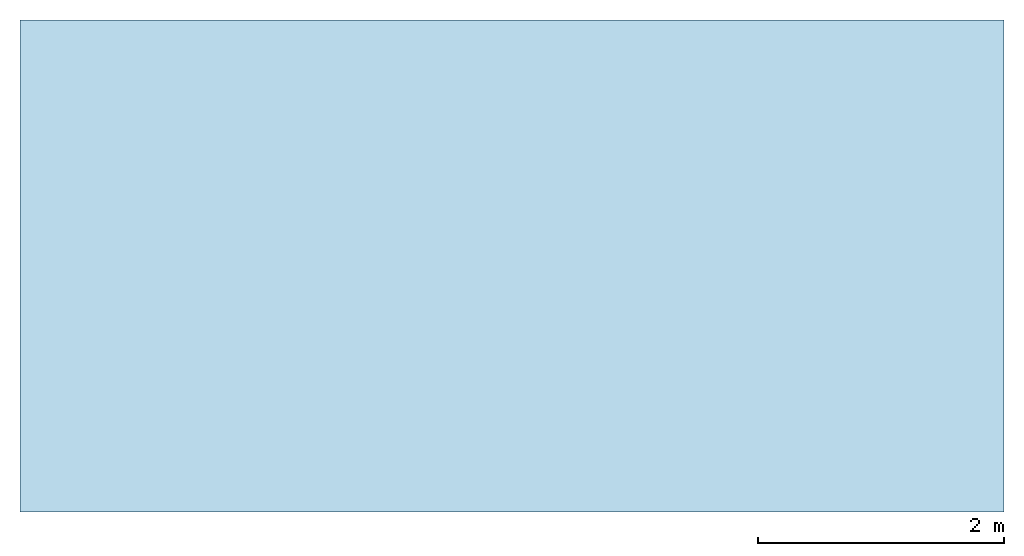
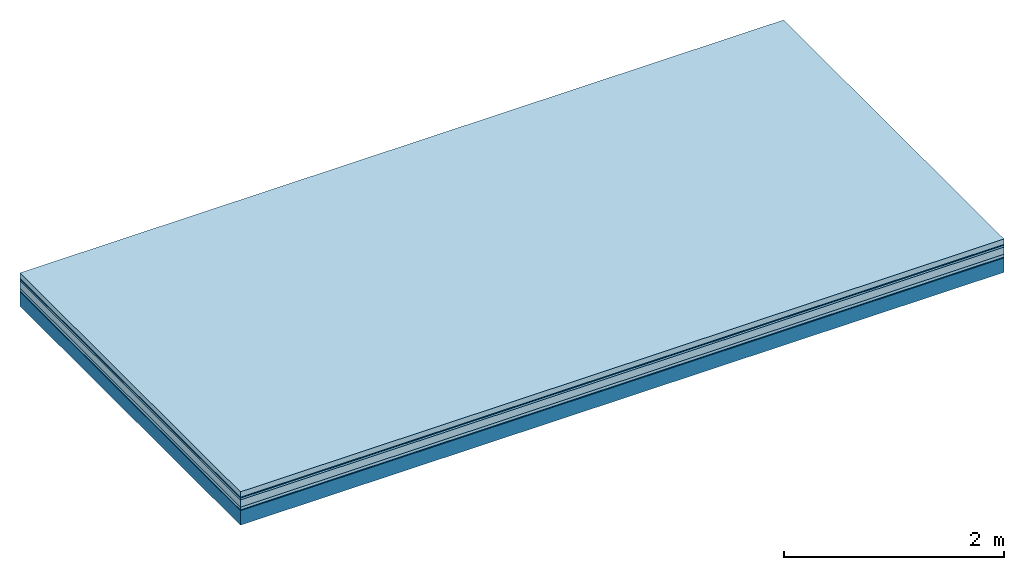
# One storey: 6 plates, 1 member, 1 element without a shape of its own.
"""IFC4 building model written with IfcOpenShell, lengths in metres."""

import ifcopenshell
import ifcopenshell.guid

model = None  # the IFC model being written
_history = None  # IfcOwnerHistory: only IFC2X3 demands one
_inside = {}  # id of a spatial element -> (the spatial element, [elements in it])
_under = {}  # id of a project, library or spatial element -> (it, [spatial elements below it])
_declared = {}  # id of a project -> (the project, [libraries it declares])
_typed = {}  # id of a type object -> (the type object, [elements of that type])
_made_of = {}  # id of a material, layer set ... -> (it, [elements and type objects made of it])


def new_model(schema):
    """Start an empty IFC model of exactly this schema.

    Asked for "IFC4X3", IfcOpenShell would pick the latest addendum, in which some entities
    have other attributes; the version numbers below select the first issue.
    IFC2X3 requires an IfcOwnerHistory on every rooted entity: one is made here for all.
    """
    global model, _history
    if schema == "IFC4X3":
        model = ifcopenshell.file(schema_version=(4, 3, 0, 0))
    else:
        model = ifcopenshell.file(schema=schema)
    _inside.clear()
    _under.clear()
    _declared.clear()
    _typed.clear()
    _made_of.clear()
    _history = None
    if model.schema == "IFC2X3":
        org = make("IfcOrganization", Name="unknown")
        user = make(
            "IfcPersonAndOrganization",
            ThePerson=make("IfcPerson", FamilyName="unknown"),
            TheOrganization=org,
        )
        app = make(
            "IfcApplication",
            ApplicationDeveloper=org,
            Version="unknown",
            ApplicationFullName="unknown",
            ApplicationIdentifier="unknown",
        )
        _history = make(
            "IfcOwnerHistory",
            OwningUser=user,
            OwningApplication=app,
            ChangeAction="ADDED",
            CreationDate=0,
        )
    return model


def make(cls, **values):
    """One entity of the class cls with the attributes given. An attribute that is None is left unset."""
    return model.create_entity(
        cls, **{name: value for name, value in values.items() if value is not None}
    )


def rooted(cls, **values):
    """An entity with a GlobalId (a new one), such as an element, a storey or a relation."""
    return make(cls, GlobalId=ifcopenshell.guid.new(), OwnerHistory=_history, **values)


def si_unit(unit_type, name, prefix=None):
    """IfcSIUnit, for example si_unit("LENGTHUNIT", "METRE", prefix="MILLI")."""
    return make("IfcSIUnit", UnitType=unit_type, Prefix=prefix, Name=name)


def derived_unit(unit_type, elements):
    """IfcDerivedUnit: a product of units, each with its exponent."""
    return make(
        "IfcDerivedUnit",
        Elements=[
            make("IfcDerivedUnitElement", Unit=unit, Exponent=power)
            for unit, power in elements
        ],
        UnitType=unit_type,
    )


def assignment(units):
    """IfcUnitAssignment: the units of a project."""
    return None if units is None else make("IfcUnitAssignment", Units=units)


def point(xyz):
    """IfcCartesianPoint."""
    return None if xyz is None else make("IfcCartesianPoint", Coordinates=xyz)


def direction(xyz):
    """IfcDirection."""
    return None if xyz is None else make("IfcDirection", DirectionRatios=xyz)


def frame(location, z_axis=None, x_axis=None):
    """IfcAxis2Placement3D, a coordinate frame: its origin and axes. An axis left out is left unset."""
    return make(
        "IfcAxis2Placement3D",
        Location=point(location),
        Axis=direction(z_axis),
        RefDirection=direction(x_axis),
    )


def frame_2d(location, x_axis=None):
    """IfcAxis2Placement2D, a coordinate frame in the plane: its origin and x axis."""
    return make(
        "IfcAxis2Placement2D", Location=point(location), RefDirection=direction(x_axis)
    )


def origin():
    """The frame at (0, 0, 0) with its axes left unset."""
    return frame((0.0, 0.0, 0.0))


def origin_with_axes():
    """The frame at (0, 0, 0) with the z axis (0, 0, 1) and the x axis (1, 0, 0) written out."""
    return frame((0.0, 0.0, 0.0), z_axis=(0.0, 0.0, 1.0), x_axis=(1.0, 0.0, 0.0))


def place(relative_to, where):
    """IfcLocalPlacement: puts the frame where relative to a parent placement (None: the world)."""
    return make(
        "IfcLocalPlacement", PlacementRelTo=relative_to, RelativePlacement=where
    )


def context(
    kind, dimensions, precision=None, world=None, true_north=None, identifier=None
):
    """IfcGeometricRepresentationContext, for example the 3D "Model" context."""
    return make(
        "IfcGeometricRepresentationContext",
        ContextIdentifier=identifier,
        ContextType=kind,
        CoordinateSpaceDimension=dimensions,
        Precision=precision,
        WorldCoordinateSystem=world,
        TrueNorth=true_north,
    )


def project(units=None, contexts=None):
    """IfcProject with its units and contexts."""
    return rooted(
        "IfcProject",
        Name="project",
        RepresentationContexts=contexts,
        UnitsInContext=assignment(units),
    )


def spatial(cls, under=None, at=None, **own):
    """A site, building, storey or space (cls), placed at a placement, below another one or the project."""
    s = rooted(cls, ObjectPlacement=at, **own)
    if under is not None:
        _under.setdefault(under.id(), (under, []))[1].append(s)
    return s


def profile(cls, at=None, kind="AREA", **sizes):
    """A parametric profile (cls). Its sizes go by their IFC names, for example OverallWidth=200.0."""
    return make(cls, ProfileType=kind, Position=at, **sizes)


def rectangle(**sizes):
    """IfcRectangleProfileDef."""
    return profile("IfcRectangleProfileDef", **sizes)


def extrude(swept, where, along, depth):
    """IfcExtrudedAreaSolid: the profile swept, set in the frame where, extruded along a direction by depth."""
    return make(
        "IfcExtrudedAreaSolid",
        SweptArea=swept,
        Position=where,
        ExtrudedDirection=direction(along),
        Depth=depth,
    )


def shape(context_of_items, identifier, shape_type, items):
    """IfcShapeRepresentation: the items that make up one representation, for example the "Body"."""
    return make(
        "IfcShapeRepresentation",
        ContextOfItems=context_of_items,
        RepresentationIdentifier=identifier,
        RepresentationType=shape_type,
        Items=items,
    )


def material(Name=None, Category=None):
    """IfcMaterial."""
    return make("IfcMaterial", Name=Name, Category=Category)


def layer(
    of_material, thickness, ventilated=None, Name=None, Category=None, Priority=None
):
    """IfcMaterialLayer: one layer of a wall or slab, of a material (None: an air gap)."""
    return make(
        "IfcMaterialLayer",
        Material=of_material,
        LayerThickness=thickness,
        IsVentilated=ventilated,
        Name=Name,
        Category=Category,
        Priority=Priority,
    )


def layer_set(layers, Name=None):
    """IfcMaterialLayerSet."""
    return make("IfcMaterialLayerSet", MaterialLayers=layers, LayerSetName=Name)


def made_of(thing, what):
    """Note that an element or type object is made of a material, layer set ...; save() writes the relation."""
    if what is not None:
        _made_of.setdefault(what.id(), (what, []))[1].append(thing)
    return thing


def type_object(cls, material=None, **own):
    """A type object (cls), such as IfcWallType, which elements share."""
    return made_of(rooted(cls, **own), material)


def element(
    cls,
    number,
    at=None,
    inside=None,
    cuts=None,
    type_object=None,
    material=None,
    context=None,
    identifier="Body",
    shape_type=None,
    held_by="IfcProductDefinitionShape",
    body=None,
    shapes=None,
    **own,
):
    """One element of the class cls, such as IfcWall. Its Tag is "e" and its number.

    at: its placement. inside: the storey or other place that contains it. cuts: it is an
    opening in that element (IfcRelVoidsElement). A single representation is given by context,
    identifier, shape_type and body (its items); several are given by shapes. held_by: the class
    of the entity that holds the representations. save() writes the other relations.
    """
    e = rooted(cls, Tag="e%d" % number, ObjectPlacement=at, **own)
    if body is not None:
        shapes = [shape(context, identifier, shape_type, body)]
    if shapes is not None:
        e.Representation = make(held_by, Representations=shapes)
    if inside is not None:
        _inside.setdefault(inside.id(), (inside, []))[1].append(e)
    if cuts is not None:
        rooted(
            "IfcRelVoidsElement", RelatingBuildingElement=cuts, RelatedOpeningElement=e
        )
    if type_object is not None:
        _typed.setdefault(type_object.id(), (type_object, []))[1].append(e)
    return made_of(e, material)


def aggregate(whole, parts):
    """IfcRelAggregates: a whole, such as a stair, and the parts it consists of."""
    return rooted("IfcRelAggregates", RelatingObject=whole, RelatedObjects=parts)


def save(model, path):
    """Write the relations noted so far, then the file.

    IfcRelAggregates (storeys below a building ...), IfcRelContainedInSpatialStructure (elements
    in a storey), IfcRelDefinesByType, IfcRelAssociatesMaterial and IfcRelDeclares: one each for
    every whole, place, type object, material and project.
    """
    for whole, parts in _under.values():
        aggregate(whole, parts)
    for where, things in _inside.values():
        rooted(
            "IfcRelContainedInSpatialStructure",
            RelatedElements=things,
            RelatingStructure=where,
        )
    for kind, things in _typed.values():
        rooted("IfcRelDefinesByType", RelatedObjects=things, RelatingType=kind)
    for what, things in _made_of.values():
        rooted("IfcRelAssociatesMaterial", RelatedObjects=things, RelatingMaterial=what)
    for by, libraries in _declared.values():
        rooted("IfcRelDeclares", RelatingContext=by, RelatedDefinitions=libraries)
    model.write(path)


model = new_model("IFC4")

# Units and contexts
plan_context = context("Plan", 3, precision=1e-05, world=origin(), true_north=direction((0.0, 1.0)))
model_context = context("Model", 3, precision=1e-05, world=origin(), true_north=direction((0.0, 1.0)))
ifc_project = project(units=[si_unit("LENGTHUNIT", "METRE"), derived_unit("SOUNDPRESSUREUNIT", [(si_unit("PRESSUREUNIT", "PASCAL", prefix="MICRO"), 0)]), si_unit("ENERGYUNIT", "JOULE", prefix="MEGA"), si_unit("MASSUNIT", "GRAM", prefix="KILO"), derived_unit("THERMALTRANSMITTANCEUNIT", [(si_unit("POWERUNIT", "WATT"), 1), (si_unit("AREAUNIT", "SQUARE_METRE"), -1), (si_unit("THERMODYNAMICTEMPERATUREUNIT", "KELVIN"), -1)]), derived_unit("AREADENSITYUNIT", [(si_unit("MASSUNIT", "GRAM", prefix="KILO"), 1), (si_unit("AREAUNIT", "SQUARE_METRE"), -1)]), derived_unit("USERDEFINED", [(si_unit("ENERGYUNIT", "JOULE", prefix="MEGA"), 1), (si_unit("AREAUNIT", "SQUARE_METRE"), -1)])], contexts=[plan_context, model_context])

# Site, building, storey
site = spatial("IfcSite", under=ifc_project)
building_placement = place(None, origin())
building = spatial("IfcBuilding", under=site, at=building_placement)
storey_placement = place(building_placement, origin())
storey = spatial("IfcBuildingStorey", under=building, at=storey_placement)

# Slab, member, plates
ifc_material_1 = material(Name="clay", Category="02.004")
ifc_layer_1 = layer(ifc_material_1, 0.06, Name="Use and protection layer 2")
ifc_material_2 = material(Name="Protective layer", Category="09.007")
ifc_layer_2 = layer(ifc_material_2, 0.01, Name="Use and protection layer 1")
ifc_material_3 = material(Name="Bituminous", Category="09.003")
ifc_layer_3 = layer(ifc_material_3, 0.02, Name="Seal")
ifc_material_4 = material(Category="10.006")
ifc_layer_4 = layer(ifc_material_4, 0.08, Name="Exterior insulation layer 2")
ifc_material_5 = material(Name="(034) 25 boards", Category="10.004")
ifc_layer_5 = layer(ifc_material_5, 0.03, Name="Exterior insulation layer 1")
ifc_material_6 = material(Name="Vapor-permeable barrier", Category="09.006")
ifc_layer_6 = layer(ifc_material_6, 0.01, Name="layer / temporary roof")
ifc_material_7 = material(Name="no composite action")
ifc_layer_7 = layer(ifc_material_7, 0.0, Name="Bond")
ifc_layer_8 = layer(None, 0.16, Name="Support")
ifc_layer_set = layer_set([ifc_layer_1, ifc_layer_2, ifc_layer_3, ifc_layer_4, ifc_layer_5, ifc_layer_6, ifc_layer_7, ifc_layer_8])
slab_type = type_object("IfcSlabType", Name="F0063", PredefinedType="NOTDEFINED", material=ifc_layer_set)
slab_placement = place(None, frame((0.0, 0.0, 0.0), z_axis=(0.0, 0.0, -1.0), x_axis=(1.0, 0.0, 0.0)))
slab = element("IfcSlab", 1, at=slab_placement, inside=storey, type_object=slab_type, material=ifc_layer_set, Name="Slab #1")
ifc_material_8 = material(Name="Solid timber panel")
member_placement = place(slab_placement, origin())
member = element("IfcMember", 2, at=member_placement, material=ifc_material_8, Name="Support", context=plan_context, shape_type="SweptSolid", body=[
    extrude(rectangle(XDim=1.0, YDim=0.16, at=frame_2d((0.5, 0.08), x_axis=(1.0, 0.0))), frame((0.0, 4.0, 0.21), z_axis=(0.0, -1.0, 0.0), x_axis=(1.0, 0.0, 0.0)), (0.0, 0.0, 1.0), 4.0),
    extrude(rectangle(XDim=1.0, YDim=0.16, at=frame_2d((0.5, 0.08), x_axis=(1.0, 0.0))), frame((1.0, 4.0, 0.21), z_axis=(0.0, -1.0, 0.0), x_axis=(1.0, 0.0, 0.0)), (0.0, 0.0, 1.0), 4.0),
    extrude(rectangle(XDim=1.0, YDim=0.16, at=frame_2d((0.5, 0.08), x_axis=(1.0, 0.0))), frame((2.0, 4.0, 0.21), z_axis=(0.0, -1.0, 0.0), x_axis=(1.0, 0.0, 0.0)), (0.0, 0.0, 1.0), 4.0),
    extrude(rectangle(XDim=1.0, YDim=0.16, at=frame_2d((0.5, 0.08), x_axis=(1.0, 0.0))), frame((3.0, 4.0, 0.21), z_axis=(0.0, -1.0, 0.0), x_axis=(1.0, 0.0, 0.0)), (0.0, 0.0, 1.0), 4.0),
    extrude(rectangle(XDim=1.0, YDim=0.16, at=frame_2d((0.5, 0.08), x_axis=(1.0, 0.0))), frame((4.0, 4.0, 0.21), z_axis=(0.0, -1.0, 0.0), x_axis=(1.0, 0.0, 0.0)), (0.0, 0.0, 1.0), 4.0),
    extrude(rectangle(XDim=1.0, YDim=0.16, at=frame_2d((0.5, 0.08), x_axis=(1.0, 0.0))), frame((5.0, 4.0, 0.21), z_axis=(0.0, -1.0, 0.0), x_axis=(1.0, 0.0, 0.0)), (0.0, 0.0, 1.0), 4.0),
    extrude(rectangle(XDim=1.0, YDim=0.16, at=frame_2d((0.5, 0.08), x_axis=(1.0, 0.0))), frame((6.0, 4.0, 0.21), z_axis=(0.0, -1.0, 0.0), x_axis=(1.0, 0.0, 0.0)), (0.0, 0.0, 1.0), 4.0),
    extrude(rectangle(XDim=1.0, YDim=0.16, at=frame_2d((0.5, 0.08), x_axis=(1.0, 0.0))), frame((7.0, 4.0, 0.21), z_axis=(0.0, -1.0, 0.0), x_axis=(1.0, 0.0, 0.0)), (0.0, 0.0, 1.0), 4.0),
])
plate_1_placement = place(slab_placement, origin())
plate_1 = element("IfcPlate", 3, at=plate_1_placement, material=ifc_material_1, Name="Use and protection layer 2", context=plan_context, shape_type="SweptSolid", body=[
    extrude(rectangle(XDim=8.0, YDim=4.0, at=frame_2d((4.0, 2.0), x_axis=(1.0, 0.0))), origin_with_axes(), (0.0, 0.0, 1.0), 0.06),
])
plate_2_placement = place(slab_placement, origin())
plate_2 = element("IfcPlate", 4, at=plate_2_placement, material=ifc_material_2, Name="Use and protection layer 1", context=plan_context, shape_type="SweptSolid", body=[
    extrude(rectangle(XDim=8.0, YDim=4.0, at=frame_2d((4.0, 2.0), x_axis=(1.0, 0.0))), frame((0.0, 0.0, 0.06), z_axis=(0.0, 0.0, 1.0), x_axis=(1.0, 0.0, 0.0)), (0.0, 0.0, 1.0), 0.01),
])
plate_3_placement = place(slab_placement, origin())
plate_3 = element("IfcPlate", 5, at=plate_3_placement, material=ifc_material_3, Name="Seal", context=plan_context, shape_type="SweptSolid", body=[
    extrude(rectangle(XDim=8.0, YDim=4.0, at=frame_2d((4.0, 2.0), x_axis=(1.0, 0.0))), frame((0.0, 0.0, 0.07), z_axis=(0.0, 0.0, 1.0), x_axis=(1.0, 0.0, 0.0)), (0.0, 0.0, 1.0), 0.02),
])
plate_4_placement = place(slab_placement, origin())
plate_4 = element("IfcPlate", 6, at=plate_4_placement, material=ifc_material_4, Name="Exterior insulation layer 2", context=plan_context, shape_type="SweptSolid", body=[
    extrude(rectangle(XDim=8.0, YDim=4.0, at=frame_2d((4.0, 2.0), x_axis=(1.0, 0.0))), frame((0.0, 0.0, 0.09), z_axis=(0.0, 0.0, 1.0), x_axis=(1.0, 0.0, 0.0)), (0.0, 0.0, 1.0), 0.08),
])
plate_5_placement = place(slab_placement, origin())
plate_5 = element("IfcPlate", 7, at=plate_5_placement, material=ifc_material_5, Name="Exterior insulation layer 1", context=plan_context, shape_type="SweptSolid", body=[
    extrude(rectangle(XDim=8.0, YDim=4.0, at=frame_2d((4.0, 2.0), x_axis=(1.0, 0.0))), frame((0.0, 0.0, 0.17), z_axis=(0.0, 0.0, 1.0), x_axis=(1.0, 0.0, 0.0)), (0.0, 0.0, 1.0), 0.03),
])
plate_6_placement = place(slab_placement, origin())
plate_6 = element("IfcPlate", 8, at=plate_6_placement, material=ifc_material_6, Name="layer / temporary roof", context=plan_context, shape_type="SweptSolid", body=[
    extrude(rectangle(XDim=8.0, YDim=4.0, at=frame_2d((4.0, 2.0), x_axis=(1.0, 0.0))), frame((0.0, 0.0, 0.2), z_axis=(0.0, 0.0, 1.0), x_axis=(1.0, 0.0, 0.0)), (0.0, 0.0, 1.0), 0.01),
])
aggregate(slab, [plate_1, plate_2, plate_3, plate_4, plate_5, plate_6, member])

save(model, "model.ifc")
